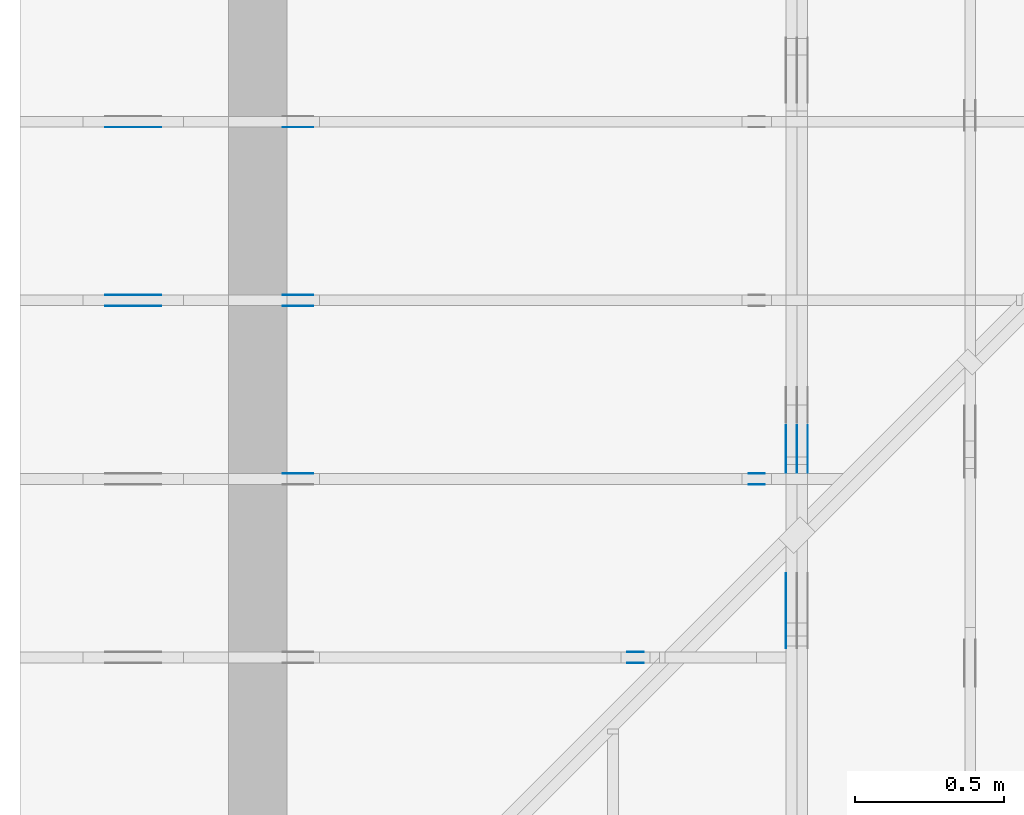
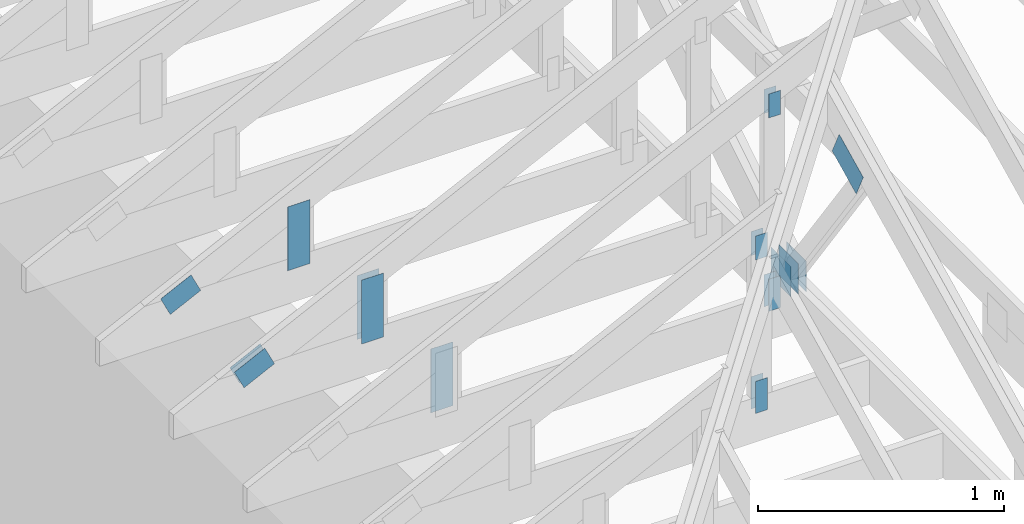
# One storey, part 58 of 159: 20 plates, 5 elements without a shape of their own.
"""IFC2X3 building model written with IfcOpenShell, lengths in millimetres."""

from ifc_helpers import new_model, si_unit, frame, origin, origin_with_axes, origin_2d, place, context, project, spatial, faceted_brep, element, aggregate, save


model = new_model("IFC2X3")

# Units and contexts
model_context = context("Model", 3, precision=1e-05, world=origin())
plan_context = context("Plan", 2, precision=1e-05, world=origin_2d())
ifc_project = project(units=[si_unit("LENGTHUNIT", "METRE", prefix="MILLI"), si_unit("AREAUNIT", "SQUARE_METRE"), si_unit("VOLUMEUNIT", "CUBIC_METRE"), si_unit("SOLIDANGLEUNIT", "STERADIAN"), si_unit("PLANEANGLEUNIT", "RADIAN"), si_unit("MASSUNIT", "GRAM"), si_unit("TIMEUNIT", "SECOND"), si_unit("THERMODYNAMICTEMPERATUREUNIT", "DEGREE_CELSIUS"), si_unit("LUMINOUSINTENSITYUNIT", "LUMEN")], contexts=[model_context, plan_context])

# Site, building, storey
site_placement = place(None, origin_with_axes())
site = spatial("IfcSite", under=ifc_project, at=site_placement, CompositionType="ELEMENT")
building_placement = place(site_placement, origin_with_axes())
building = spatial("IfcBuilding", under=site, at=building_placement, Name="Plan 1", CompositionType="ELEMENT")
storey_placement = place(building_placement, origin_with_axes())
storey = spatial("IfcBuildingStorey", under=building, at=storey_placement, Name="Etasje 1", CompositionType="ELEMENT", Elevation=0.0)

# Assembly, plates
assembly_1_placement = place(storey_placement, frame((-700.000000000007, 3282.0074014212605, 1.1021457184401395e-15), z_axis=(0.0, -1.0, 6.123031769111886e-17), x_axis=(1.0, 0.0, 0.0)))
assembly_1 = element("IfcElementAssembly", 1, at=assembly_1_placement, inside=storey, Name="S3 (19)", AssemblyPlace="FACTORY", PredefinedType="TRUSS")
plate_1_placement = place(assembly_1_placement, frame((331.11001837023963, 141.861590425104, 0.0), z_axis=(0.0, 0.0, 1.0), x_axis=(0.898794046299167, 0.4383711467890774, 0.0)))
plate_1 = element("IfcPlate", 2, at=plate_1_placement, Name="GNT100S 103x159", context=model_context, shape_type="Brep", body=[
    faceted_brep([(158.9999891847673, 103.00001264929412, 1.0), (1.0551442869655148e-05, 103.00001264929412, 1.0), (3.169461194829637e-06, 1.220379553501516e-05, 1.0), (159.00000923180312, 1.220379553501516e-05, 1.0), (1.0551442869655148e-05, 103.00001264929412, 1.2921363980173511e-21), (158.9999891847673, 103.00001264929412, 1.9471239701335528e-14), (159.00000923180312, 0.0, 1.9471242156308275e-14), (3.169461194829637e-06, 0.0, 3.881342317381837e-22), (159.0000000000001, 1.1149113816269815e-05, 4.8075085841285717e-32), (159.0000000000001, 1.1149113816331046e-05, 1.0), (5.684341886080802e-14, 1.1149113845537907e-05, 1.0), (5.684341886080802e-14, 1.1149113845476677e-05, 0.0), (159.0000000000001, 103.00001114911387, 6.310887241768095e-30), (159.0000000000001, 103.00001114911387, 1.0), (159.0000000000001, 1.1149113817054968e-05, 1.0), (159.0000000000001, 1.1149113817054968e-05, 0.0), (0.0, 103.00001114911385, 0.0), (0.0, 103.00001114911385, 1.0), (159.0, 103.00001114911387, 1.0), (159.0, 103.00001114911387, 0.0), (5.684342142788343e-14, 1.1149113845476677e-05, -1.5718284369734698e-37), (5.690465174557455e-14, 1.1149113845476677e-05, 1.0), (2.3776908575388583e-14, 103.00001114911385, 1.0), (2.3715678257697464e-14, 103.00001114911385, -1.4521185139791763e-30)], [[[0, 1, 2, 3]], [[4, 5, 6, 7]], [[8, 9, 10, 11]], [[12, 13, 14, 15]], [[16, 17, 18, 19]], [[20, 21, 22, 23]]]),
])
plate_2_placement = place(assembly_1_placement, frame((986.0125131974362, 165.43966674804688, 0.0), z_axis=(0.0, 0.0, 1.0), x_axis=(6.123031769111886e-17, 1.0, 0.0)))
plate_2 = element("IfcPlate", 3, at=plate_2_placement, Name="GNT100S 103x317", context=model_context, shape_type="Brep", body=[
    faceted_brep([(317.0, 103.00000099040494, 1.0), (0.0, 103.00000099040494, 1.0), (0.0, 9.90404942058376e-07, 1.0), (317.0, 9.90404942058376e-07, 1.0), (0.0, 103.00000099040494, 0.0), (317.0, 103.00000099040494, 3.882002141616936e-14), (317.0, 9.90404942058376e-07, 3.882002141616936e-14), (0.0, 9.90404942058376e-07, 0.0), (317.0000058634298, -5.823003320131305e-14, 3.565443432080797e-30), (317.0000058634298, -5.816880288362193e-14, 1.0), (5.8634298056858825e-06, 6.122924063210958e-17, 1.0), (5.8634298056858825e-06, -1.0770590092851658e-21, 6.594866531061244e-38), (317.0000058634298, 103.0, 0.0), (317.0000058634298, 103.0, 1.0), (317.0000058634298, 0.0, 1.0), (317.0000058634298, 0.0, 0.0), (5.8634298056858825e-06, 103.0, 0.0), (5.8634298056858825e-06, 103.0, 1.0), (317.0000058634298, 102.99999999999999, 1.0), (317.0000058634298, 102.99999999999999, -1.5777218104420236e-30), (5.8634298056858825e-06, 0.0, 0.0), (5.863429805747113e-06, -7.498303609110687e-33, 1.0), (5.863429818360558e-06, 103.0, 1.0), (5.863429818299328e-06, 103.0, -7.723252732077687e-31)], [[[0, 1, 2, 3]], [[4, 5, 6, 7]], [[8, 9, 10, 11]], [[12, 13, 14, 15]], [[16, 17, 18, 19]], [[20, 21, 22, 23]]]),
])
aggregate(assembly_1, [plate_1, plate_2])

assembly_2_placement = place(storey_placement, frame((-700.000000000007, 1482.0074014212605, 1.1021457184401395e-15), z_axis=(0.0, -1.0, 6.123031769111886e-17), x_axis=(1.0, 0.0, 0.0)))
assembly_2 = element("IfcElementAssembly", 4, at=assembly_2_placement, inside=storey, Name="S6 (18)", AssemblyPlace="FACTORY", PredefinedType="TRUSS")
plate_3_placement = place(assembly_2_placement, frame((2040.5946044921875, 1023.5120849609375, 0.0), z_axis=(0.0, 0.0, 1.0), x_axis=(6.123031769111886e-17, -1.0, 0.0)))
plate_3 = element("IfcPlate", 5, at=plate_3_placement, Name="GNT100S 55x119", context=model_context, shape_type="Brep", body=[
    faceted_brep([(119.0, 55.0001220703125, 1.0), (0.0, 55.0001220703125, 1.0), (0.0, 0.0, 1.0), (119.0, 0.0, 1.0), (0.0, 55.0001220703125, 0.0), (119.0, 55.0001220703125, 1.457281561048629e-14), (119.0, 0.0, 1.457281561048629e-14), (0.0, 0.0, 0.0), (119.00001837208049, 3.8814971936486045e-05, 1.3384475843434453e-30), (119.00001837208049, 3.8814971936547275e-05, 1.0), (1.837208048982575e-05, 3.88149719584065e-05, 1.0), (1.837208048982575e-05, 3.881497195834527e-05, 3.76158192263132e-37), (119.00001837208049, 55.00003881497196, 0.0), (119.00001837208049, 55.00003881497196, 1.0), (119.00001837208049, 3.881497195834527e-05, 1.0), (119.00001837208049, 3.881497195834527e-05, 0.0), (1.837208048982575e-05, 55.00003881497196, 0.0), (1.837208048982575e-05, 55.00003881497196, 1.0), (119.00001837208049, 55.00003881497195, 1.0), (119.00001837208049, 55.00003881497195, -3.944304526105059e-31), (1.8372080489825752e-05, 3.881497195834527e-05, -3.76158192263132e-37), (1.8372080489886982e-05, 3.881497195834527e-05, 1.0), (1.8372080496622317e-05, 55.00003881497196, 1.0), (1.8372080496561087e-05, 55.00003881497196, -4.12407052618761e-31)], [[[0, 1, 2, 3]], [[4, 5, 6, 7]], [[8, 9, 10, 11]], [[12, 13, 14, 15]], [[16, 17, 18, 19]], [[20, 21, 22, 23]]]),
])
plate_4_placement = place(assembly_2_placement, frame((2040.5946044921875, 1023.5120849609375, -37.0), z_axis=(0.0, 0.0, 1.0), x_axis=(6.123031769111886e-17, -1.0, 0.0)))
plate_4 = element("IfcPlate", 6, at=plate_4_placement, Name="GNT100S 55x119", context=model_context, shape_type="Brep", body=[
    faceted_brep([(119.0, 55.0001220703125, 1.0), (0.0, 55.0001220703125, 1.0), (0.0, 0.0, 1.0), (119.0, 0.0, 1.0), (0.0, 55.0001220703125, 0.0), (119.0, 55.0001220703125, 1.457281561048629e-14), (119.0, 0.0, 1.457281561048629e-14), (0.0, 0.0, 0.0), (119.00001837208049, 3.8814971936486045e-05, 1.3384475843434453e-30), (119.00001837208049, 3.8814971936547275e-05, 1.0), (1.837208048982575e-05, 3.88149719584065e-05, 1.0), (1.837208048982575e-05, 3.881497195834527e-05, 3.76158192263132e-37), (119.00001837208049, 55.00003881497196, 0.0), (119.00001837208049, 55.00003881497196, 1.0), (119.00001837208049, 3.881497195834527e-05, 1.0), (119.00001837208049, 3.881497195834527e-05, 0.0), (1.837208048982575e-05, 55.00003881497196, 0.0), (1.837208048982575e-05, 55.00003881497196, 1.0), (119.00001837208049, 55.00003881497195, 1.0), (119.00001837208049, 55.00003881497195, -3.944304526105059e-31), (1.8372080489825752e-05, 3.881497195834527e-05, -3.76158192263132e-37), (1.8372080489886982e-05, 3.881497195834527e-05, 1.0), (1.8372080496622317e-05, 55.00003881497196, 1.0), (1.8372080496561087e-05, 55.00003881497196, -4.12407052618761e-31)], [[[0, 1, 2, 3]], [[4, 5, 6, 7]], [[8, 9, 10, 11]], [[12, 13, 14, 15]], [[16, 17, 18, 19]], [[20, 21, 22, 23]]]),
])
plate_5_placement = place(assembly_2_placement, frame((2095.5947265625, 143.49999999999997, 0.0), z_axis=(0.0, 0.0, 1.0), x_axis=(6.123031769111886e-17, 1.0, 0.0)))
plate_5 = element("IfcPlate", 7, at=plate_5_placement, Name="GNT100S 55x159", context=model_context, shape_type="Brep", body=[
    faceted_brep([(159.0, 55.0001220703125, 1.0), (0.0, 55.0001220703125, 1.0), (2.842170943040401e-14, 0.0, 1.0), (159.0, 0.0, 1.0), (0.0, 55.0001220703125, 0.0), (159.0, 55.0001220703125, 1.9471241025775798e-14), (159.0, 0.0, 1.9471241025775798e-14), (2.842170943040401e-14, 0.0, 3.4805405954966126e-30), (159.00000000018042, 8.325534869790019e-05, 1.788345571668688e-30), (159.00000000018042, 8.325534869796142e-05, 1.0), (1.8044943317363504e-10, 8.325534872716828e-05, 1.0), (1.8044943317363504e-10, 8.325534872710705e-05, 0.0), (159.00000000018042, 55.00008325534873, 0.0), (159.00000000018042, 55.00008325534873, 1.0), (159.00000000018042, 8.325534872710705e-05, 1.0), (159.00000000018042, 8.325534872710705e-05, 0.0), (1.8042101146420464e-10, 55.00008325534873, 0.0), (1.8042101146420464e-10, 55.00008325534873, 1.0), (159.00000000018042, 55.00008325534872, 1.0), (159.00000000018042, 55.00008325534872, -7.888609052210118e-31), (1.8044943318988064e-10, 8.325534872710705e-05, -9.947233512834192e-37), (1.8044949442019833e-10, 8.325534872710705e-05, 1.0), (1.804318048486026e-10, 55.00008325534873, 1.0), (1.804317436182849e-10, 55.00008325534873, -6.5713320384529466e-31)], [[[0, 1, 2, 3]], [[4, 5, 6, 7]], [[8, 9, 10, 11]], [[12, 13, 14, 15]], [[16, 17, 18, 19]], [[20, 21, 22, 23]]]),
])
plate_6_placement = place(assembly_2_placement, frame((2095.5947265625, 143.49999999999997, -37.0), z_axis=(0.0, 0.0, 1.0), x_axis=(6.123031769111886e-17, 1.0, 0.0)))
plate_6 = element("IfcPlate", 8, at=plate_6_placement, Name="GNT100S 55x159", context=model_context, shape_type="Brep", body=[
    faceted_brep([(159.0, 55.0001220703125, 1.0), (0.0, 55.0001220703125, 1.0), (2.842170943040401e-14, 0.0, 1.0), (159.0, 0.0, 1.0), (0.0, 55.0001220703125, 0.0), (159.0, 55.0001220703125, 1.9471241025775798e-14), (159.0, 0.0, 1.9471241025775798e-14), (2.842170943040401e-14, 0.0, 3.4805405954966126e-30), (159.00000000018042, 8.325534869790019e-05, 1.788345571668688e-30), (159.00000000018042, 8.325534869796142e-05, 1.0), (1.8044943317363504e-10, 8.325534872716828e-05, 1.0), (1.8044943317363504e-10, 8.325534872710705e-05, 0.0), (159.00000000018042, 55.00008325534873, 0.0), (159.00000000018042, 55.00008325534873, 1.0), (159.00000000018042, 8.325534872710705e-05, 1.0), (159.00000000018042, 8.325534872710705e-05, 0.0), (1.8042101146420464e-10, 55.00008325534873, 0.0), (1.8042101146420464e-10, 55.00008325534873, 1.0), (159.00000000018042, 55.00008325534872, 1.0), (159.00000000018042, 55.00008325534872, -7.888609052210118e-31), (1.8044943318988064e-10, 8.325534872710705e-05, -9.947233512834192e-37), (1.8044949442019833e-10, 8.325534872710705e-05, 1.0), (1.804318048486026e-10, 55.00008325534873, 1.0), (1.804317436182849e-10, 55.00008325534873, -6.5713320384529466e-31)], [[[0, 1, 2, 3]], [[4, 5, 6, 7]], [[8, 9, 10, 11]], [[12, 13, 14, 15]], [[16, 17, 18, 19]], [[20, 21, 22, 23]]]),
])
aggregate(assembly_2, [plate_3, plate_4, plate_5, plate_6])

assembly_3_placement = place(storey_placement, frame((-700.000000000007, 2682.0074014212605, 1.1021457184401395e-15), z_axis=(0.0, -1.0, 6.123031769111886e-17), x_axis=(1.0, 0.0, 0.0)))
assembly_3 = element("IfcElementAssembly", 9, at=assembly_3_placement, inside=storey, Name="S4 (17)", AssemblyPlace="FACTORY", PredefinedType="TRUSS")
plate_7_placement = place(assembly_3_placement, frame((331.11001837023963, 141.861590425104, 0.0), z_axis=(0.0, 0.0, 1.0), x_axis=(0.898794046299167, 0.4383711467890774, 0.0)))
plate_7 = element("IfcPlate", 10, at=plate_7_placement, Name="GNT100S 103x159", context=model_context, shape_type="Brep", body=[
    faceted_brep([(158.9999891847673, 103.00001264929412, 1.0), (1.0551442869655148e-05, 103.00001264929412, 1.0), (3.169461194829637e-06, 1.220379553501516e-05, 1.0), (159.00000923180312, 1.220379553501516e-05, 1.0), (1.0551442869655148e-05, 103.00001264929412, 1.2921363980173511e-21), (158.9999891847673, 103.00001264929412, 1.9471239701335528e-14), (159.00000923180312, 0.0, 1.9471242156308275e-14), (3.169461194829637e-06, 0.0, 3.881342317381837e-22), (159.0, 1.1149113773637251e-05, -8.220600630328674e-31), (159.0, 1.1149113773698482e-05, 1.0), (1.124750610685991e-32, 1.1149113802905343e-05, 1.0), (0.0, 1.1149113802844113e-05, 0.0), (159.0, 103.00001114911382, 0.0), (159.0, 103.00001114911382, 1.0), (159.0, 1.1149113760211549e-05, 1.0), (159.0, 1.1149113760211549e-05, 0.0), (0.0, 103.00001114911379, 0.0), (0.0, 103.00001114911379, 1.0), (159.0, 103.00001114911382, 1.0), (159.0, 103.00001114911382, 0.0), (1.3653275602451668e-21, 1.1149113802844113e-05, -8.359944026625179e-38), (6.12316830186791e-17, 1.1149113802844113e-05, 1.0), (1.2674677127389164e-14, 103.00001114911379, 1.0), (1.2613446809698045e-14, 103.00001114911379, -7.72325355337841e-31)], [[[0, 1, 2, 3]], [[4, 5, 6, 7]], [[8, 9, 10, 11]], [[12, 13, 14, 15]], [[16, 17, 18, 19]], [[20, 21, 22, 23]]]),
])
plate_8_placement = place(assembly_3_placement, frame((331.11001837023963, 141.861590425104, -37.00000000000001), z_axis=(0.0, 0.0, 1.0), x_axis=(0.898794046299167, 0.4383711467890774, 0.0)))
plate_8 = element("IfcPlate", 11, at=plate_8_placement, Name="GNT100S 103x159", context=model_context, shape_type="Brep", body=[
    faceted_brep([(158.9999891847673, 103.00001264929412, 1.0), (1.0551442869655148e-05, 103.00001264929412, 1.0), (3.169461194829637e-06, 1.220379553501516e-05, 1.0), (159.00000923180312, 1.220379553501516e-05, 1.0), (1.0551442869655148e-05, 103.00001264929412, 1.2921363980173511e-21), (158.9999891847673, 103.00001264929412, 1.9471239701335528e-14), (159.00000923180312, 0.0, 1.9471242156308275e-14), (3.169461194829637e-06, 0.0, 3.881342317381837e-22), (159.0, 1.1149113773637251e-05, -8.220600630328674e-31), (159.0, 1.1149113773698482e-05, 1.0), (1.124750610685991e-32, 1.1149113802905343e-05, 1.0), (0.0, 1.1149113802844113e-05, 0.0), (159.0, 103.00001114911382, 0.0), (159.0, 103.00001114911382, 1.0), (159.0, 1.1149113760211549e-05, 1.0), (159.0, 1.1149113760211549e-05, 0.0), (0.0, 103.00001114911379, 0.0), (0.0, 103.00001114911379, 1.0), (159.0, 103.00001114911382, 1.0), (159.0, 103.00001114911382, 0.0), (1.3653275602451668e-21, 1.1149113802844113e-05, -8.359944026625179e-38), (6.12316830186791e-17, 1.1149113802844113e-05, 1.0), (1.2674677127389164e-14, 103.00001114911379, 1.0), (1.2613446809698045e-14, 103.00001114911379, -7.72325355337841e-31)], [[[0, 1, 2, 3]], [[4, 5, 6, 7]], [[8, 9, 10, 11]], [[12, 13, 14, 15]], [[16, 17, 18, 19]], [[20, 21, 22, 23]]]),
])
plate_9_placement = place(assembly_3_placement, frame((986.0125131972193, 165.43966674804688, 0.0), z_axis=(0.0, 0.0, 1.0), x_axis=(6.123031769111886e-17, 1.0, 0.0)))
plate_9 = element("IfcPlate", 12, at=plate_9_placement, Name="GNT100S 103x317", context=model_context, shape_type="Brep", body=[
    faceted_brep([(317.0, 103.00000099018803, 1.0), (0.0, 103.00000099018803, 1.0), (0.0, 9.901880275720032e-07, 1.0), (317.0, 9.901880275720032e-07, 1.0), (0.0, 103.00000099018803, 0.0), (317.0, 103.00000099018803, 3.882002141616936e-14), (317.0, 9.901880275720032e-07, 3.882002141616936e-14), (0.0, 9.901880275720032e-07, 0.0), (317.00000586342503, -5.823003320131217e-14, 3.5654434320807435e-30), (317.00000586342503, -5.816880288362106e-14, 1.0), (5.863425030838698e-06, 6.122924063298667e-17, 1.0), (5.863425030838698e-06, -1.0770581321889357e-21, 6.594861160573163e-38), (317.00000586342503, 103.0, 0.0), (317.00000586342503, 103.0, 1.0), (317.00000586342503, 0.0, 1.0), (317.00000586342503, 0.0, 0.0), (5.863425030838698e-06, 103.0, 0.0), (5.863425030838698e-06, 103.0, 1.0), (317.00000586342503, 102.99999999999999, 1.0), (317.00000586342503, 102.99999999999999, -1.5777218104420236e-30), (5.863425030838698e-06, 0.0, 0.0), (5.8634250308999285e-06, -7.498303609110687e-33, 1.0), (5.863425043513374e-06, 103.0, 1.0), (5.863425043452144e-06, 103.0, -7.723252732077687e-31)], [[[0, 1, 2, 3]], [[4, 5, 6, 7]], [[8, 9, 10, 11]], [[12, 13, 14, 15]], [[16, 17, 18, 19]], [[20, 21, 22, 23]]]),
])
plate_10_placement = place(assembly_3_placement, frame((986.0125131972193, 165.43966674804688, -37.0), z_axis=(0.0, 0.0, 1.0), x_axis=(6.123031769111886e-17, 1.0, 0.0)))
plate_10 = element("IfcPlate", 13, at=plate_10_placement, Name="GNT100S 103x317", context=model_context, shape_type="Brep", body=[
    faceted_brep([(317.0, 103.00000099018803, 1.0), (0.0, 103.00000099018803, 1.0), (0.0, 9.901880275720032e-07, 1.0), (317.0, 9.901880275720032e-07, 1.0), (0.0, 103.00000099018803, 0.0), (317.0, 103.00000099018803, 3.882002141616936e-14), (317.0, 9.901880275720032e-07, 3.882002141616936e-14), (0.0, 9.901880275720032e-07, 0.0), (317.00000586342503, -5.823003320131217e-14, 3.5654434320807435e-30), (317.00000586342503, -5.816880288362106e-14, 1.0), (5.863425030838698e-06, 6.122924063298667e-17, 1.0), (5.863425030838698e-06, -1.0770581321889357e-21, 6.594861160573163e-38), (317.00000586342503, 103.0, 0.0), (317.00000586342503, 103.0, 1.0), (317.00000586342503, 0.0, 1.0), (317.00000586342503, 0.0, 0.0), (5.863425030838698e-06, 103.0, 0.0), (5.863425030838698e-06, 103.0, 1.0), (317.00000586342503, 102.99999999999999, 1.0), (317.00000586342503, 102.99999999999999, -1.5777218104420236e-30), (5.863425030838698e-06, 0.0, 0.0), (5.8634250308999285e-06, -7.498303609110687e-33, 1.0), (5.863425043513374e-06, 103.0, 1.0), (5.863425043452144e-06, 103.0, -7.723252732077687e-31)], [[[0, 1, 2, 3]], [[4, 5, 6, 7]], [[8, 9, 10, 11]], [[12, 13, 14, 15]], [[16, 17, 18, 19]], [[20, 21, 22, 23]]]),
])
aggregate(assembly_3, [plate_7, plate_8, plate_9, plate_10])

assembly_4_placement = place(storey_placement, frame((-700.000000000007, 2082.0074014212605, 1.1021457184401395e-15), z_axis=(0.0, -1.0, 6.123031769111886e-17), x_axis=(1.0, 0.0, 0.0)))
assembly_4 = element("IfcElementAssembly", 14, at=assembly_4_placement, inside=storey, Name="S5 (10)", AssemblyPlace="FACTORY", PredefinedType="TRUSS")
plate_11_placement = place(assembly_4_placement, frame((2448.522216796875, 1222.4716796875, 0.0), z_axis=(0.0, 0.0, 1.0), x_axis=(6.123031769111886e-17, -1.0, 0.0)))
plate_11 = element("IfcPlate", 15, at=plate_11_placement, Name="GNT100S 55x119", context=model_context, shape_type="Brep", body=[
    faceted_brep([(119.0, 55.0, 1.0), (0.0, 55.0, 1.0), (0.0, 0.0, 1.0), (119.0, 0.0, 1.0), (0.0, 55.0, 0.0), (119.0, 55.0, 1.457281561048629e-14), (119.0, 0.0, 1.457281561048629e-14), (0.0, 0.0, 0.0), (119.00001997601612, 4.460969828502632e-05, 1.3384475843434453e-30), (119.00001997601612, 4.460969828508755e-05, 1.0), (1.997601611947175e-05, 4.460969830694677e-05, 1.0), (1.997601611947175e-05, 4.460969830688554e-05, 3.76158192263132e-37), (119.00001997601612, 55.00004460969831, 0.0), (119.00001997601612, 55.00004460969831, 1.0), (119.00001997601612, 4.460969830688555e-05, 1.0), (119.00001997601612, 4.460969830688555e-05, 0.0), (1.997601611947175e-05, 55.00004460969831, 0.0), (1.997601611947175e-05, 55.00004460969831, 1.0), (119.00001997601612, 55.0000446096983, 1.0), (119.00001997601612, 55.0000446096983, -3.944304526105059e-31), (1.9976016119471758e-05, 4.460969830688555e-05, -3.76158192263132e-37), (1.9976016119532988e-05, 4.460969830688555e-05, 1.0), (1.9976016126268323e-05, 55.00004460969831, 1.0), (1.9976016126207093e-05, 55.00004460969831, -4.12407052618761e-31)], [[[0, 1, 2, 3]], [[4, 5, 6, 7]], [[8, 9, 10, 11]], [[12, 13, 14, 15]], [[16, 17, 18, 19]], [[20, 21, 22, 23]]]),
])
plate_12_placement = place(assembly_4_placement, frame((2448.522216796875, 1222.4716796875, -37.0), z_axis=(0.0, 0.0, 1.0), x_axis=(6.123031769111886e-17, -1.0, 0.0)))
plate_12 = element("IfcPlate", 16, at=plate_12_placement, Name="GNT100S 55x119", context=model_context, shape_type="Brep", body=[
    faceted_brep([(119.0, 55.0, 1.0), (0.0, 55.0, 1.0), (0.0, 0.0, 1.0), (119.0, 0.0, 1.0), (0.0, 55.0, 0.0), (119.0, 55.0, 1.457281561048629e-14), (119.0, 0.0, 1.457281561048629e-14), (0.0, 0.0, 0.0), (119.00001997601612, 4.460969828502632e-05, 1.3384475843434453e-30), (119.00001997601612, 4.460969828508755e-05, 1.0), (1.997601611947175e-05, 4.460969830694677e-05, 1.0), (1.997601611947175e-05, 4.460969830688554e-05, 3.76158192263132e-37), (119.00001997601612, 55.00004460969831, 0.0), (119.00001997601612, 55.00004460969831, 1.0), (119.00001997601612, 4.460969830688555e-05, 1.0), (119.00001997601612, 4.460969830688555e-05, 0.0), (1.997601611947175e-05, 55.00004460969831, 0.0), (1.997601611947175e-05, 55.00004460969831, 1.0), (119.00001997601612, 55.0000446096983, 1.0), (119.00001997601612, 55.0000446096983, -3.944304526105059e-31), (1.9976016119471758e-05, 4.460969830688555e-05, -3.76158192263132e-37), (1.9976016119532988e-05, 4.460969830688555e-05, 1.0), (1.9976016126268323e-05, 55.00004460969831, 1.0), (1.9976016126207093e-05, 55.00004460969831, -4.12407052618761e-31)], [[[0, 1, 2, 3]], [[4, 5, 6, 7]], [[8, 9, 10, 11]], [[12, 13, 14, 15]], [[16, 17, 18, 19]], [[20, 21, 22, 23]]]),
])
plate_13_placement = place(assembly_4_placement, frame((2503.522261406586, 143.5, 0.0), z_axis=(0.0, 0.0, 1.0), x_axis=(6.123031769111886e-17, 1.0, 0.0)))
plate_13 = element("IfcPlate", 17, at=plate_13_placement, Name="GNT100S 55x159", context=model_context, shape_type="Brep", body=[
    faceted_brep([(159.00000000000003, 55.00004460971104, 1.0), (0.0, 55.00004460971104, 1.0), (0.0, 4.460971103981137e-05, 1.0), (159.00000000000003, 4.460971103981137e-05, 1.0), (0.0, 55.00004460971104, 0.0), (159.00000000000003, 55.00004460971104, 1.94712410257758e-14), (159.00000000000003, 4.460971103981137e-05, 1.94712410257758e-14), (0.0, 4.460971103981137e-05, 0.0), (159.0000000000197, -2.9206861538667314e-14, 1.7883454107731203e-30), (159.0000000000197, -2.9145631220976195e-14, 1.0), (1.9696244635269977e-11, 6.123031768750084e-17, 1.0), (1.9696244635269977e-11, -3.618021949018729e-27, 2.2153263335185782e-43), (159.0000000000197, 55.0, 0.0), (159.0000000000197, 55.0, 1.0), (159.0000000000197, 0.0, 1.0), (159.0000000000197, 0.0, 0.0), (1.9696244635269977e-11, 55.0, 0.0), (1.9696244635269977e-11, 55.0, 1.0), (159.0000000000197, 54.99999999999999, 1.0), (159.0000000000197, 54.99999999999999, -7.888609052210118e-31), (1.9696244635269977e-11, 0.0, 0.0), (1.9696305865587668e-11, -7.498303609110687e-33, 1.0), (1.970304120053369e-11, 55.0, 1.0), (1.9702979970216e-11, 55.0, -4.124066985010878e-31)], [[[0, 1, 2, 3]], [[4, 5, 6, 7]], [[8, 9, 10, 11]], [[12, 13, 14, 15]], [[16, 17, 18, 19]], [[20, 21, 22, 23]]]),
])
plate_14_placement = place(assembly_4_placement, frame((2503.522261406586, 143.5, -37.0), z_axis=(0.0, 0.0, 1.0), x_axis=(6.123031769111886e-17, 1.0, 0.0)))
plate_14 = element("IfcPlate", 18, at=plate_14_placement, Name="GNT100S 55x159", context=model_context, shape_type="Brep", body=[
    faceted_brep([(159.00000000000003, 55.00004460971104, 1.0), (0.0, 55.00004460971104, 1.0), (0.0, 4.460971103981137e-05, 1.0), (159.00000000000003, 4.460971103981137e-05, 1.0), (0.0, 55.00004460971104, 0.0), (159.00000000000003, 55.00004460971104, 1.94712410257758e-14), (159.00000000000003, 4.460971103981137e-05, 1.94712410257758e-14), (0.0, 4.460971103981137e-05, 0.0), (159.0000000000197, -2.9206861538667314e-14, 1.7883454107731203e-30), (159.0000000000197, -2.9145631220976195e-14, 1.0), (1.9696244635269977e-11, 6.123031768750084e-17, 1.0), (1.9696244635269977e-11, -3.618021949018729e-27, 2.2153263335185782e-43), (159.0000000000197, 55.0, 0.0), (159.0000000000197, 55.0, 1.0), (159.0000000000197, 0.0, 1.0), (159.0000000000197, 0.0, 0.0), (1.9696244635269977e-11, 55.0, 0.0), (1.9696244635269977e-11, 55.0, 1.0), (159.0000000000197, 54.99999999999999, 1.0), (159.0000000000197, 54.99999999999999, -7.888609052210118e-31), (1.9696244635269977e-11, 0.0, 0.0), (1.9696305865587668e-11, -7.498303609110687e-33, 1.0), (1.970304120053369e-11, 55.0, 1.0), (1.9702979970216e-11, 55.0, -4.124066985010878e-31)], [[[0, 1, 2, 3]], [[4, 5, 6, 7]], [[8, 9, 10, 11]], [[12, 13, 14, 15]], [[16, 17, 18, 19]], [[20, 21, 22, 23]]]),
])
plate_15_placement = place(assembly_4_placement, frame((986.0125131976704, 165.43966674804688, -37.0), z_axis=(0.0, 0.0, 1.0), x_axis=(6.123031769111886e-17, 1.0, 0.0)))
plate_15 = element("IfcPlate", 19, at=plate_15_placement, Name="GNT100S 103x317", context=model_context, shape_type="Brep", body=[
    faceted_brep([(317.0, 103.00000099063914, 1.0), (0.0, 103.00000099063914, 1.0), (0.0, 9.906391369440826e-07, 1.0), (317.0, 9.906391369440826e-07, 1.0), (0.0, 103.00000099063914, 0.0), (317.0, 103.00000099063914, 3.882002141616936e-14), (317.0, 9.906391369440826e-07, 3.882002141616936e-14), (0.0, 9.906391369440826e-07, 0.0), (317.0000058634356, -5.823003320131412e-14, 3.565443432080862e-30), (317.0000058634356, -5.8168802883623e-14, 1.0), (5.863435603714606e-06, 6.122924063104454e-17, 1.0), (5.863435603714606e-06, -1.077060074330588e-21, 6.5948730523682e-38), (317.0000058634356, 103.0, 0.0), (317.0000058634356, 103.0, 1.0), (317.0000058634356, 0.0, 1.0), (317.0000058634356, 0.0, 0.0), (5.863435603714606e-06, 103.0, 0.0), (5.863435603714606e-06, 103.0, 1.0), (317.0000058634356, 102.99999999999999, 1.0), (317.0000058634356, 102.99999999999999, -1.5777218104420236e-30), (5.863435603714606e-06, 0.0, 0.0), (5.863435603775837e-06, -7.498303609110687e-33, 1.0), (5.863435616389282e-06, 103.0, 1.0), (5.863435616328052e-06, 103.0, -7.723252732077687e-31)], [[[0, 1, 2, 3]], [[4, 5, 6, 7]], [[8, 9, 10, 11]], [[12, 13, 14, 15]], [[16, 17, 18, 19]], [[20, 21, 22, 23]]]),
])
aggregate(assembly_4, [plate_11, plate_12, plate_13, plate_14, plate_15])

assembly_5_placement = place(storey_placement, frame((1875.0222614047502, 9699.999999999993, 0.0), z_axis=(-1.0, 1.836909530733566e-16, 6.123031769111886e-17), x_axis=(-1.836909530733566e-16, -1.0, 0.0)))
assembly_5 = element("IfcElementAssembly", 20, at=assembly_5_placement, inside=storey, Name="V1 (2)", AssemblyPlace="FACTORY", PredefinedType="TRUSS")
plate_16_placement = place(assembly_5_placement, frame((7578.91380688237, 299.0000000004002, 0.0), z_axis=(0.0, 0.0, 1.0), x_axis=(-1.0, 1.2246063538223773e-16, 0.0)))
plate_16 = element("IfcPlate", 21, at=plate_16_placement, Name="GNT100S 152x159", context=model_context, shape_type="Brep", body=[
    faceted_brep([(159.0002326636204, 152.00000000040015, 1.0), (0.00023266362040885724, 152.00000000040015, 1.0), (0.00023266362040885724, 4.001776687800884e-10, 1.0), (159.0002326636204, 4.001776687800884e-10, 1.0), (0.00023266362040885724, 152.00000000040015, 2.849213478560043e-20), (159.0002326636204, 152.00000000040015, 1.9471269517910585e-14), (159.0002326636204, 4.001776687800884e-10, 1.9471269517910585e-14), (0.00023266362040885724, 4.001776687800884e-10, 2.849213478560043e-20), (159.0, -2.92068615386637e-14, 1.788345410772899e-30), (159.0, -2.914563122097258e-14, 1.0), (1.1247455413666031e-32, 6.123031769111886e-17, 1.0), (0.0, 0.0, 0.0), (159.0, 152.0, 0.0), (159.0, 152.0, 1.0), (159.0, 0.0, 1.0), (159.0, 0.0, 0.0), (0.0, 151.99999999999997, 0.0), (0.0, 151.99999999999997, 1.0), (159.0, 152.0, 1.0), (159.0, 152.0, 0.0), (0.0, 0.0, 0.0), (6.123031769111886e-17, -7.498303609110687e-33, 1.0), (1.867524689579125e-14, 151.99999999999997, 1.0), (1.861401657810013e-14, 151.99999999999997, -1.1397421485848243e-30)], [[[0, 1, 2, 3]], [[4, 5, 6, 7]], [[8, 9, 10, 11]], [[12, 13, 14, 15]], [[16, 17, 18, 19]], [[20, 21, 22, 23]]]),
])
plate_17_placement = place(assembly_5_placement, frame((7578.91380688237, 299.0000000004002, -37.0), z_axis=(0.0, 0.0, 1.0), x_axis=(-1.0, 1.2246063538223773e-16, 0.0)))
plate_17 = element("IfcPlate", 22, at=plate_17_placement, Name="GNT100S 152x159", context=model_context, shape_type="Brep", body=[
    faceted_brep([(159.0002326636204, 152.00000000040015, 1.0), (0.00023266362040885724, 152.00000000040015, 1.0), (0.00023266362040885724, 4.001776687800884e-10, 1.0), (159.0002326636204, 4.001776687800884e-10, 1.0), (0.00023266362040885724, 152.00000000040015, 2.849213478560043e-20), (159.0002326636204, 152.00000000040015, 1.9471269517910585e-14), (159.0002326636204, 4.001776687800884e-10, 1.9471269517910585e-14), (0.00023266362040885724, 4.001776687800884e-10, 2.849213478560043e-20), (159.0, -2.92068615386637e-14, 1.788345410772899e-30), (159.0, -2.914563122097258e-14, 1.0), (1.1247455413666031e-32, 6.123031769111886e-17, 1.0), (0.0, 0.0, 0.0), (159.0, 152.0, 0.0), (159.0, 152.0, 1.0), (159.0, 0.0, 1.0), (159.0, 0.0, 0.0), (0.0, 151.99999999999997, 0.0), (0.0, 151.99999999999997, 1.0), (159.0, 152.0, 1.0), (159.0, 152.0, 0.0), (0.0, 0.0, 0.0), (6.123031769111886e-17, -7.498303609110687e-33, 1.0), (1.867524689579125e-14, 151.99999999999997, 1.0), (1.861401657810013e-14, 151.99999999999997, -1.1397421485848243e-30)], [[[0, 1, 2, 3]], [[4, 5, 6, 7]], [[8, 9, 10, 11]], [[12, 13, 14, 15]], [[16, 17, 18, 19]], [[20, 21, 22, 23]]]),
])
plate_18_placement = place(assembly_5_placement, frame((7578.91380688237, 299.0000000004002, -36.0), z_axis=(0.0, 0.0, 1.0), x_axis=(-1.0, 1.2246063538223773e-16, 0.0)))
plate_18 = element("IfcPlate", 23, at=plate_18_placement, Name="GNT100S 152x159", context=model_context, shape_type="Brep", body=[
    faceted_brep([(159.0002326636204, 152.00000000040015, 1.0), (0.00023266362040885724, 152.00000000040015, 1.0), (0.00023266362040885724, 4.001776687800884e-10, 1.0), (159.0002326636204, 4.001776687800884e-10, 1.0), (0.00023266362040885724, 152.00000000040015, 2.849213478560043e-20), (159.0002326636204, 152.00000000040015, 1.9471269517910585e-14), (159.0002326636204, 4.001776687800884e-10, 1.9471269517910585e-14), (0.00023266362040885724, 4.001776687800884e-10, 2.849213478560043e-20), (159.0, -2.92068615386637e-14, 1.788345410772899e-30), (159.0, -2.914563122097258e-14, 1.0), (1.1247455413666031e-32, 6.123031769111886e-17, 1.0), (0.0, 0.0, 0.0), (159.0, 152.0, 0.0), (159.0, 152.0, 1.0), (159.0, 0.0, 1.0), (159.0, 0.0, 0.0), (0.0, 151.99999999999997, 0.0), (0.0, 151.99999999999997, 1.0), (159.0, 152.0, 1.0), (159.0, 152.0, 0.0), (0.0, 0.0, 0.0), (6.123031769111886e-17, -7.498303609110687e-33, 1.0), (1.867524689579125e-14, 151.99999999999997, 1.0), (1.861401657810013e-14, 151.99999999999997, -1.1397421485848243e-30)], [[[0, 1, 2, 3]], [[4, 5, 6, 7]], [[8, 9, 10, 11]], [[12, 13, 14, 15]], [[16, 17, 18, 19]], [[20, 21, 22, 23]]]),
])
plate_19_placement = place(assembly_5_placement, frame((7578.91380688237, 299.0000000004002, -73.0), z_axis=(0.0, 0.0, 1.0), x_axis=(-1.0, 1.2246063538223773e-16, 0.0)))
plate_19 = element("IfcPlate", 24, at=plate_19_placement, Name="GNT100S 152x159", context=model_context, shape_type="Brep", body=[
    faceted_brep([(159.0002326636204, 152.00000000040015, 1.0), (0.00023266362040885724, 152.00000000040015, 1.0), (0.00023266362040885724, 4.001776687800884e-10, 1.0), (159.0002326636204, 4.001776687800884e-10, 1.0), (0.00023266362040885724, 152.00000000040015, 2.849213478560043e-20), (159.0002326636204, 152.00000000040015, 1.9471269517910585e-14), (159.0002326636204, 4.001776687800884e-10, 1.9471269517910585e-14), (0.00023266362040885724, 4.001776687800884e-10, 2.849213478560043e-20), (159.0, -2.92068615386637e-14, 1.788345410772899e-30), (159.0, -2.914563122097258e-14, 1.0), (1.1247455413666031e-32, 6.123031769111886e-17, 1.0), (0.0, 0.0, 0.0), (159.0, 152.0, 0.0), (159.0, 152.0, 1.0), (159.0, 0.0, 1.0), (159.0, 0.0, 0.0), (0.0, 151.99999999999997, 0.0), (0.0, 151.99999999999997, 1.0), (159.0, 152.0, 1.0), (159.0, 152.0, 0.0), (0.0, 0.0, 0.0), (6.123031769111886e-17, -7.498303609110687e-33, 1.0), (1.867524689579125e-14, 151.99999999999997, 1.0), (1.861401657810013e-14, 151.99999999999997, -1.1397421485848243e-30)], [[[0, 1, 2, 3]], [[4, 5, 6, 7]], [[8, 9, 10, 11]], [[12, 13, 14, 15]], [[16, 17, 18, 19]], [[20, 21, 22, 23]]]),
])
plate_20_placement = place(assembly_5_placement, frame((8169.93408203125, 1098.640380859375, 0.0), z_axis=(0.0, 0.0, 1.0), x_axis=(-0.898794046299167, 0.4383711467890773, 0.0)))
plate_20 = element("IfcPlate", 25, at=plate_20_placement, Name="GNT100S 130x218", context=model_context, shape_type="Brep", body=[
    faceted_brep([(217.99994580164912, 129.9999913300544, 1.0), (4.001814977527829e-05, 129.9999913300544, 1.0), (0.0, 0.0, 1.0), (218.0003714038312, 0.0, 1.0), (4.001814977527829e-05, 129.9999913300544, 4.900648048302133e-21), (217.99994580164912, 129.9999913300544, 2.669641187616334e-14), (218.0003714038312, 0.0001462031186747481, 2.6696463995676974e-14), (0.0, 0.0001462031186747481, 0.0), (218.00016647495795, 6.290958477254247e-05, 2.451947303498846e-30), (218.00016647495795, 6.29095847726037e-05, 1.0), (0.00016647495795041323, 6.290958481264833e-05, 1.0), (0.00016647495795041323, 6.29095848125871e-05, 1.504632769052528e-36), (218.00016647495795, 130.0000629095848, -5.522026336547083e-29), (218.00016647495795, 130.0000629095848, 1.0), (218.00016647495795, 6.290958481258713e-05, 1.0), (218.00016647495795, 6.290958481258713e-05, 0.0), (0.00016647495795041323, 130.0000629095848, 0.0), (0.00016647495795041323, 130.0000629095848, 1.0), (218.00016647495886, 130.0000629095848, 1.0), (218.00016647495886, 130.0000629095848, -1.5777218104420236e-30), (0.00016647495795041323, 6.290958481258713e-05, 0.0), (0.00016647495795047446, 6.290958481258713e-05, 1.0), (0.00016647495796639434, 130.0000629095848, 1.0), (0.0001664749579663331, 130.0000629095848, -9.747793486962184e-31)], [[[0, 1, 2, 3]], [[4, 5, 6, 7]], [[8, 9, 10, 11]], [[12, 13, 14, 15]], [[16, 17, 18, 19]], [[20, 21, 22, 23]]]),
])
aggregate(assembly_5, [plate_16, plate_17, plate_18, plate_19, plate_20])

save(model, "model.ifc")
